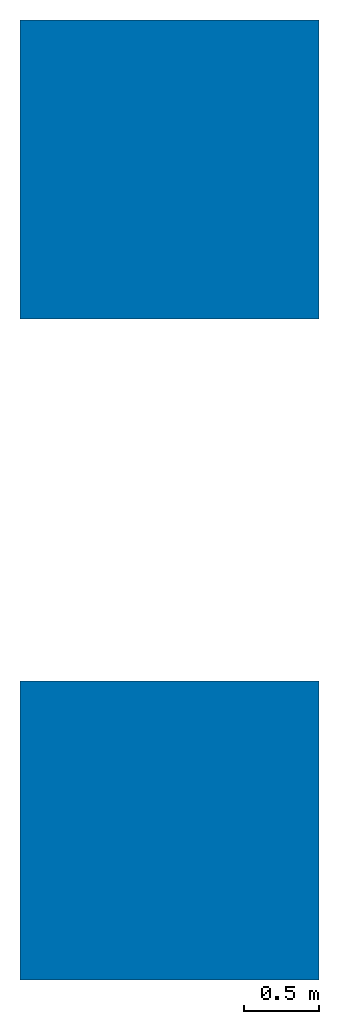
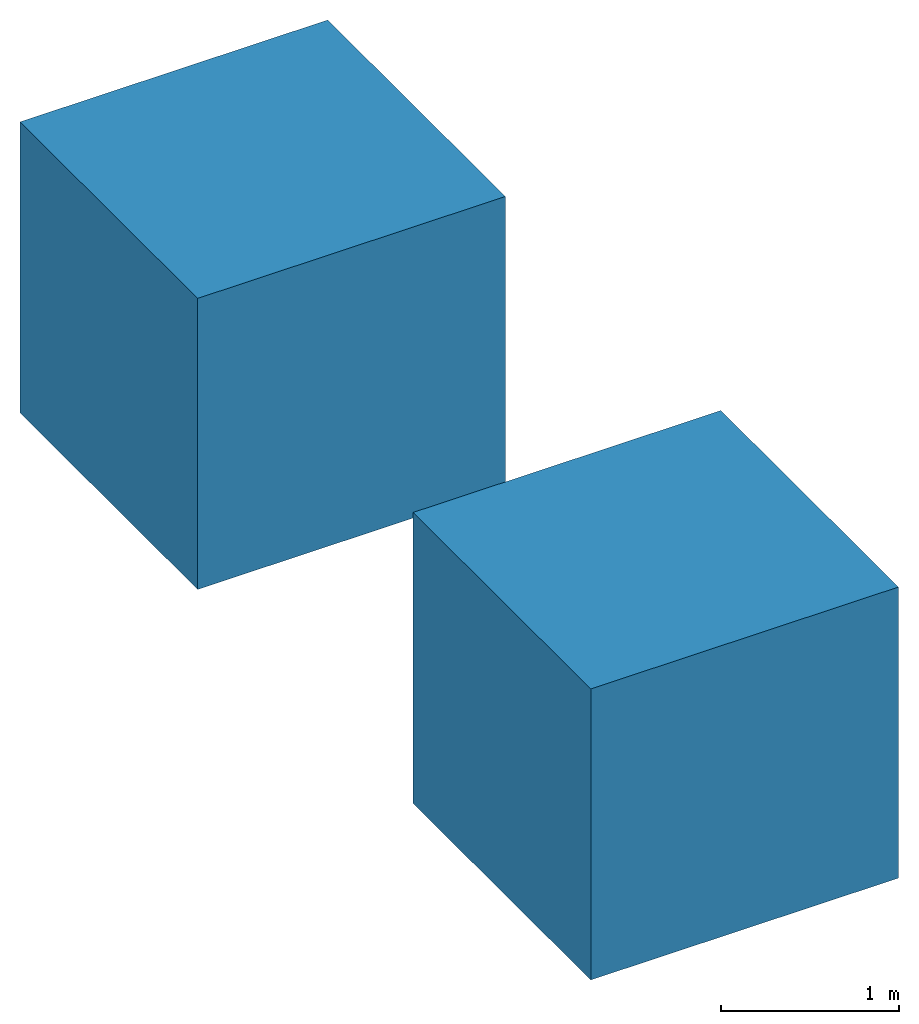
# One storey: 2 walls.
"""IFC4 building model written with IfcOpenShell, lengths in feet."""

from ifc_helpers import new_model, entity, si_unit, converted_unit, frame, origin_with_axes, place, context, subcontext, project, spatial, faceted_brep, source, transform, mapped, material, element, save


model = new_model("IFC4")

# Units and contexts
model_context = context("Model", 3, precision=1e-05, world=origin_with_axes())
body_context = subcontext(model_context, "Body", "Model", "MODEL_VIEW")
ifc_project = project(units=[converted_unit("LENGTHUNIT", "foot", entity("IfcReal", 0.3048), si_unit("LENGTHUNIT", "METRE"), dimensions=[1, 0, 0, 0, 0, 0, 0]), converted_unit("AREAUNIT", "square foot", entity("IfcReal", 0.0929), si_unit("AREAUNIT", "SQUARE_METRE"), dimensions=[2, 0, 0, 0, 0, 0, 0]), converted_unit("VOLUMEUNIT", "cubic foot", entity("IfcReal", 0.02832), si_unit("VOLUMEUNIT", "CUBIC_METRE"), dimensions=[3, 0, 0, 0, 0, 0, 0])], contexts=[model_context])

# Site, building, storey
site_placement = place(None, origin_with_axes())
site = spatial("IfcSite", under=ifc_project, at=site_placement)
building_placement = place(site_placement, origin_with_axes())
building = spatial("IfcBuilding", under=site, at=building_placement, Name="Building")
storey_placement = place(building_placement, origin_with_axes())
storey = spatial("IfcBuildingStorey", under=building, at=storey_placement, Name="Ground Floor")

# Walls
ifc_material = material(Name="Material")
shared_shape = source(origin_with_axes(), body_context, "Body", "Brep", [
    faceted_brep([(3.28083992004395, 3.28083992004395, 3.28083992004395), (-3.28083992004395, 3.28083992004395, 3.28083992004395), (-3.28083992004395, -3.28083992004395, 3.28083992004395), (3.28083992004395, -3.28083992004395, 3.28083992004395), (3.28083992004395, -3.28083992004395, -3.28083992004395), (-3.28083992004395, -3.28083992004395, -3.28083992004395), (-3.28083992004395, 3.28083992004395, -3.28083992004395), (3.28083992004395, 3.28083992004395, -3.28083992004395)], [[[0, 1, 2, 3]], [[4, 3, 2, 5]], [[5, 2, 1, 6]], [[6, 7, 4, 5]], [[7, 0, 3, 4]], [[6, 1, 0, 7]]]),
])
for number, where, z_axis, x_axis, name in (
    (1, (0.0, 0.0, 0.0), (0.0, 0.0, 1.0), (1.0, 0.0, 0.0), "Cube"),
    (2, (0.0, 14.5191298382176, 0.0), (0.0, 0.0, 1.0), (1.0, 0.0, 0.0), "Cube.001"),
):
    element("IfcWall", number, at=place(storey_placement, frame(where, z_axis=z_axis, x_axis=x_axis)), inside=storey, material=ifc_material, Name=name, PredefinedType="NOTDEFINED", context=body_context, shape_type="MappedRepresentation", body=[
        mapped(shared_shape, transform((0.0, 0.0, 0.0), x_axis=(1.0, 0.0, 0.0), y_axis=(0.0, 1.0, 0.0), z_axis=(0.0, 0.0, 1.0), scale=1.0)),
    ])

save(model, "model.ifc")
